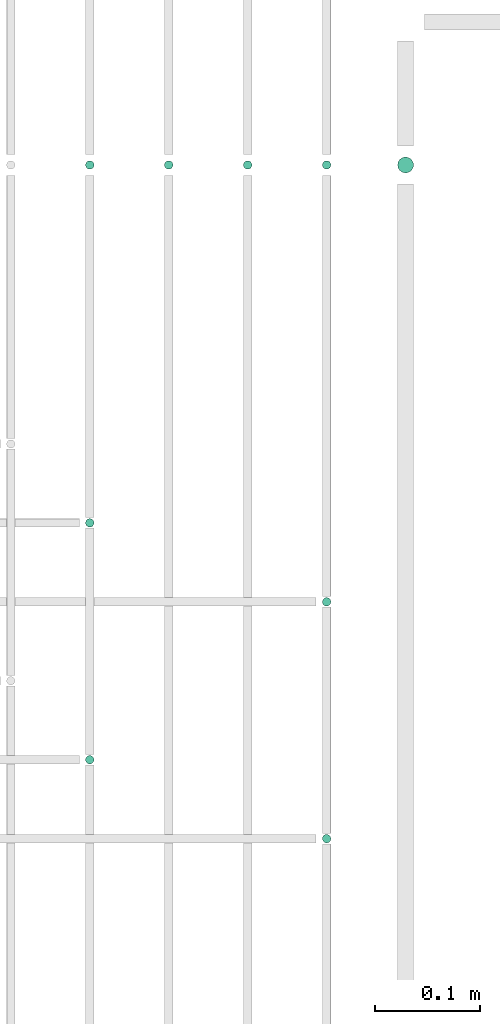
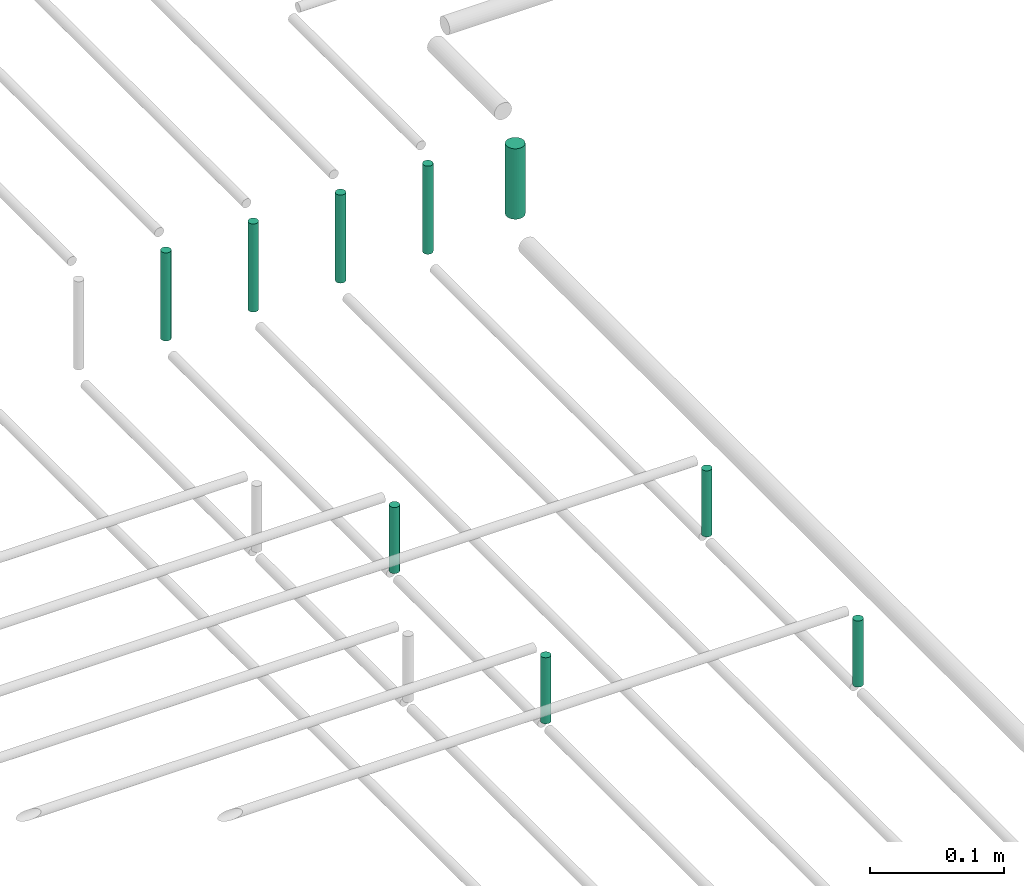
# One storey, part 82 of 89: 9 flow segments.
"""IFC2X3 building model written with IfcOpenShell, lengths in millimetres."""

from ifc_helpers import new_model, entity, si_unit, converted_unit, derived_unit, direction, frame, frame_2d, origin, origin_2d_with_axis, place, context, subcontext, project, spatial, circle, extrude, type_object, element, save


model = new_model("IFC2X3")

# Units and contexts
model_context = context("Model", 3, precision=0.01, world=origin(), true_north=direction((6.12303176911189e-17, 1.0)))
body_context = subcontext(model_context, "Body", "Model", "MODEL_VIEW")
ifc_project = project(units=[si_unit("LENGTHUNIT", "METRE", prefix="MILLI"), si_unit("AREAUNIT", "SQUARE_METRE"), si_unit("VOLUMEUNIT", "CUBIC_METRE"), converted_unit("PLANEANGLEUNIT", "DEGREE", entity("IfcRatioMeasure", 0.0174532925199433), si_unit("PLANEANGLEUNIT", "RADIAN"), dimensions=[0, 0, 0, 0, 0, 0, 0]), si_unit("MASSUNIT", "GRAM", prefix="KILO"), derived_unit("MASSDENSITYUNIT", [(si_unit("MASSUNIT", "GRAM", prefix="KILO"), 1), (si_unit("LENGTHUNIT", "METRE"), -3)]), derived_unit("MOMENTOFINERTIAUNIT", [(si_unit("LENGTHUNIT", "METRE"), 4)]), si_unit("TIMEUNIT", "SECOND"), si_unit("FREQUENCYUNIT", "HERTZ"), si_unit("THERMODYNAMICTEMPERATUREUNIT", "DEGREE_CELSIUS"), derived_unit("THERMALTRANSMITTANCEUNIT", [(si_unit("MASSUNIT", "GRAM", prefix="KILO"), 1), (si_unit("THERMODYNAMICTEMPERATUREUNIT", "KELVIN"), -1), (si_unit("TIMEUNIT", "SECOND"), -3)]), derived_unit("VOLUMETRICFLOWRATEUNIT", [(si_unit("LENGTHUNIT", "METRE"), 3), (si_unit("TIMEUNIT", "SECOND"), -1)]), derived_unit("MASSFLOWRATEUNIT", [(si_unit("MASSUNIT", "GRAM", prefix="KILO"), 1), (si_unit("TIMEUNIT", "SECOND"), -1)]), derived_unit("ROTATIONALFREQUENCYUNIT", [(si_unit("TIMEUNIT", "SECOND"), -1)]), si_unit("ELECTRICCURRENTUNIT", "AMPERE"), si_unit("ELECTRICVOLTAGEUNIT", "VOLT"), si_unit("POWERUNIT", "WATT"), si_unit("FORCEUNIT", "NEWTON", prefix="KILO"), si_unit("ILLUMINANCEUNIT", "LUX"), si_unit("LUMINOUSFLUXUNIT", "LUMEN"), si_unit("LUMINOUSINTENSITYUNIT", "CANDELA"), derived_unit("USERDEFINED", [(si_unit("MASSUNIT", "GRAM", prefix="KILO"), -1), (si_unit("LENGTHUNIT", "METRE"), -2), (si_unit("TIMEUNIT", "SECOND"), 3), (si_unit("LUMINOUSFLUXUNIT", "LUMEN"), 1)]), derived_unit("LINEARVELOCITYUNIT", [(si_unit("LENGTHUNIT", "METRE"), 1), (si_unit("TIMEUNIT", "SECOND"), -1)]), si_unit("PRESSUREUNIT", "PASCAL"), derived_unit("USERDEFINED", [(si_unit("LENGTHUNIT", "METRE"), -2), (si_unit("MASSUNIT", "GRAM", prefix="KILO"), 1), (si_unit("TIMEUNIT", "SECOND"), -2)]), derived_unit("LINEARFORCEUNIT", [(si_unit("MASSUNIT", "GRAM", prefix="KILO"), 1), (si_unit("LENGTHUNIT", "METRE"), 1), (si_unit("TIMEUNIT", "SECOND"), -2), (si_unit("LENGTHUNIT", "METRE"), -1)]), derived_unit("PLANARFORCEUNIT", [(si_unit("MASSUNIT", "GRAM", prefix="KILO"), 1), (si_unit("LENGTHUNIT", "METRE"), 1), (si_unit("TIMEUNIT", "SECOND"), -2), (si_unit("LENGTHUNIT", "METRE"), -2)])], contexts=[model_context])

# Site, building, storey
site_placement = place(None, frame((0.0, -0.00077364408347762, 0.0)))
site = spatial("IfcSite", under=ifc_project, at=site_placement, CompositionType="ELEMENT")
building_placement = place(site_placement, origin())
building = spatial("IfcBuilding", under=site, at=building_placement, CompositionType="ELEMENT")
storey_placement = place(building_placement, frame((0.0, 0.0, 24000.0)))
storey = spatial("IfcBuildingStorey", under=building, at=storey_placement, CompositionType="ELEMENT", Elevation=24000.0)

# Flow segments
pipe_segment_type = type_object("IfcPipeSegmentType", PredefinedType="NOTDEFINED")
flow_segment_1_placement = place(storey_placement, frame((67739.4049963189, 8294.3939590899, 2605.0)))
element("IfcFlowSegment", 1, at=flow_segment_1_placement, inside=storey, type_object=pipe_segment_type, context=body_context, shape_type="SweptSolid", body=[
    extrude(circle(Radius=4.0, at=frame_2d((0.0, -1.08286712929839e-12), x_axis=(1.0, 0.0))), frame((5.59527223591499, 5.59527223591499, 0.0), z_axis=(0.0, 0.0, 1.0), x_axis=(-1.0, 0.0, 0.0)), (0.0, 0.0, 1.0), 59.9999999999864),
])
flow_segment_2_placement = place(storey_placement, frame((67964.4049963189, 8219.39395908989, 2605.0)))
element("IfcFlowSegment", 2, at=flow_segment_2_placement, inside=storey, type_object=pipe_segment_type, context=body_context, shape_type="SweptSolid", body=[
    extrude(circle(Radius=4.0, at=frame_2d((0.0, 1.08286712929839e-12), x_axis=(1.0, 0.0))), frame((5.59527223591499, 5.59527223591716, 0.0), z_axis=(0.0, 0.0, 1.0), x_axis=(-1.0, 0.0, 0.0)), (0.0, 0.0, 1.0), 59.9999999999864),
])
flow_segment_3_placement = place(storey_placement, frame((67739.4049963189, 8069.3939590899, 2605.0)))
element("IfcFlowSegment", 3, at=flow_segment_3_placement, inside=storey, type_object=pipe_segment_type, context=body_context, shape_type="SweptSolid", body=[
    extrude(circle(Radius=4.0, at=origin_2d_with_axis()), frame((5.59527223591499, 5.59527223591607, 0.0)), (0.0, 0.0, 1.0), 59.9999999999864),
])
flow_segment_4_placement = place(storey_placement, frame((67964.4049963189, 7994.39395908989, 2605.0)))
element("IfcFlowSegment", 4, at=flow_segment_4_placement, inside=storey, type_object=pipe_segment_type, context=body_context, shape_type="SweptSolid", body=[
    extrude(circle(Radius=4.0, at=frame_2d((0.0, -1.08286712929839e-12), x_axis=(1.0, 0.0))), frame((5.59527223591499, 5.59527223591716, 0.0)), (0.0, 0.0, 1.0), 59.9999999999864),
])
flow_segment_5_placement = place(storey_placement, frame((67739.4049963189, 8634.40472776385, 2610.0)))
element("IfcFlowSegment", 5, at=flow_segment_5_placement, inside=storey, type_object=pipe_segment_type, context=body_context, shape_type="SweptSolid", body=[
    extrude(circle(Radius=4.0, at=origin_2d_with_axis()), frame((5.59527223591499, 5.59527223591607, 0.0), z_axis=(0.0, 0.0, 1.0), x_axis=(-1.0, 0.0, 0.0)), (0.0, 0.0, 1.0), 80.0000000000121),
])
for number, where in (
    (6, (67814.4049963189, 8634.40472776385, 2610.0)),
    (7, (67889.4049963189, 8634.40472776385, 2610.0)),
):
    element("IfcFlowSegment", number, at=place(storey_placement, frame(where)), inside=storey, type_object=pipe_segment_type, context=body_context, shape_type="SweptSolid", body=[
        extrude(circle(Radius=4.0, at=origin_2d_with_axis()), frame((5.59527223591499, 5.59527223591607, 0.0), z_axis=(0.0, 0.0, 1.0), x_axis=(-1.0, 0.0, 0.0)), (0.0, 0.0, 1.0), 80.0000000000208),
    ])
flow_segment_6_placement = place(storey_placement, frame((67964.4049963189, 8634.40472776385, 2610.0)))
element("IfcFlowSegment", 8, at=flow_segment_6_placement, inside=storey, type_object=pipe_segment_type, context=body_context, shape_type="SweptSolid", body=[
    extrude(circle(Radius=4.0, at=origin_2d_with_axis()), frame((5.59527223591499, 5.59527223591607, 0.0), z_axis=(0.0, 0.0, 1.0), x_axis=(-1.0, 0.0, 0.0)), (0.0, 0.0, 1.0), 80.0000000000121),
])
flow_segment_7_placement = place(storey_placement, frame((68035.9049963189, 8630.90472776385, 2618.0)))
element("IfcFlowSegment", 9, at=flow_segment_7_placement, inside=storey, type_object=pipe_segment_type, context=body_context, shape_type="SweptSolid", body=[
    extrude(circle(Radius=7.5, at=origin_2d_with_axis()), frame((9.09527223591419, 9.09527223591636, 0.0), z_axis=(0.0, 0.0, 1.0), x_axis=(-1.0, 0.0, 0.0)), (0.0, 0.0, 1.0), 64.0000000000028),
])

save(model, "model.ifc")
